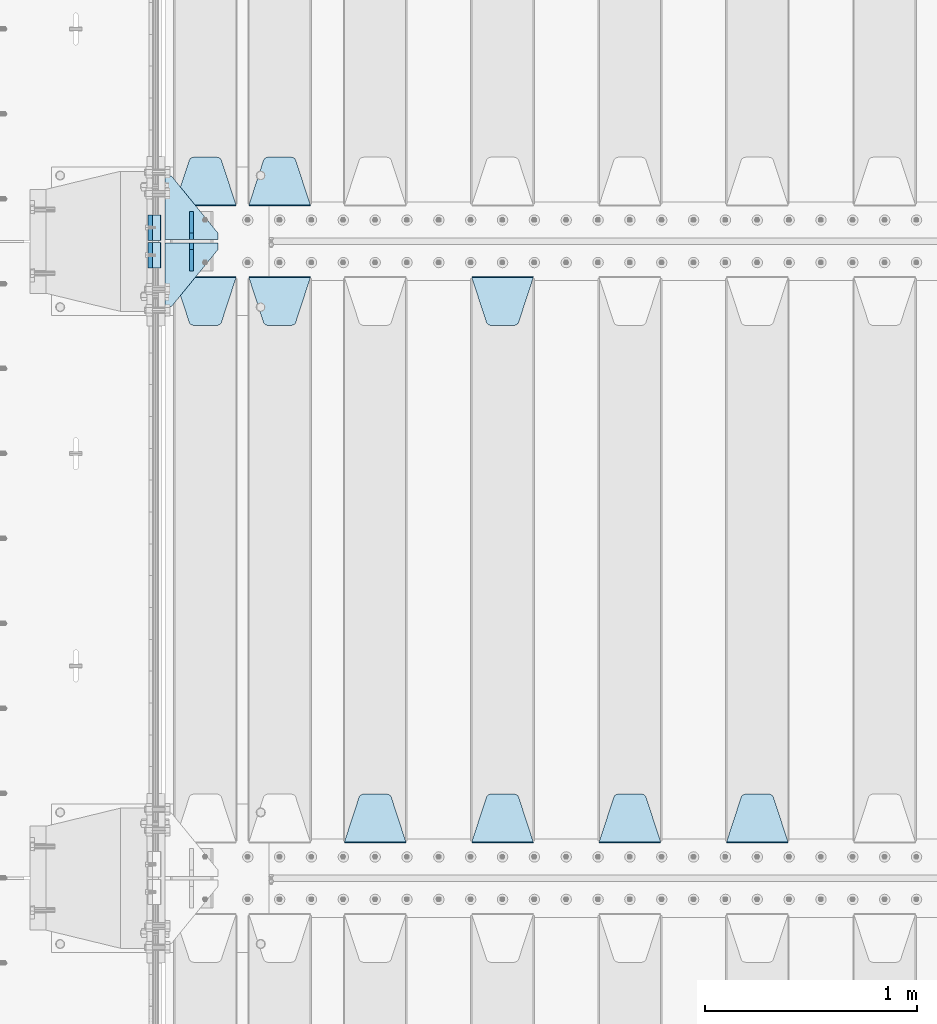
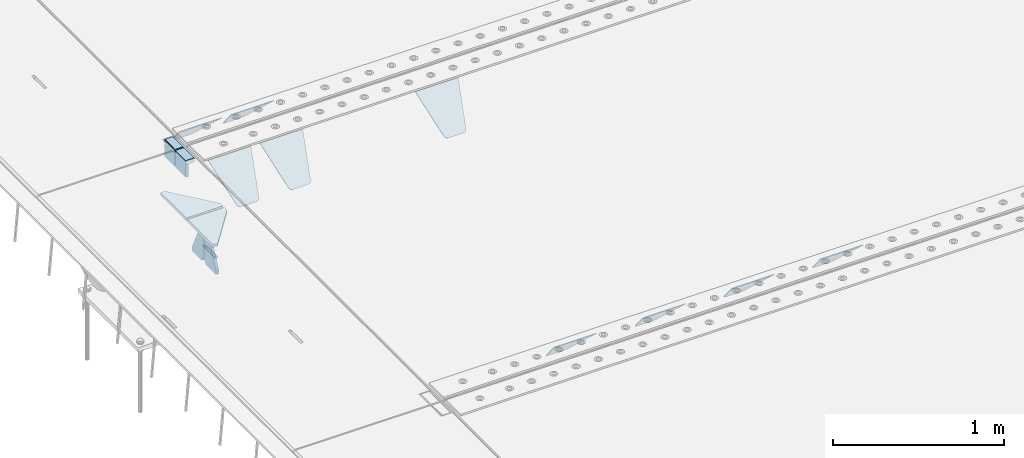
# One storey, part 194 of 240: 17 plates.
"""IFC2X3 building model written with IfcOpenShell, lengths in millimetres."""

import ifcopenshell
import ifcopenshell.guid

model = None  # the IFC model being written
_history = None  # IfcOwnerHistory: only IFC2X3 demands one
_inside = {}  # id of a spatial element -> (the spatial element, [elements in it])
_under = {}  # id of a project, library or spatial element -> (it, [spatial elements below it])
_declared = {}  # id of a project -> (the project, [libraries it declares])
_typed = {}  # id of a type object -> (the type object, [elements of that type])
_made_of = {}  # id of a material, layer set ... -> (it, [elements and type objects made of it])


def new_model(schema):
    """Start an empty IFC model of exactly this schema.

    Asked for "IFC4X3", IfcOpenShell would pick the latest addendum, in which some entities
    have other attributes; the version numbers below select the first issue.
    IFC2X3 requires an IfcOwnerHistory on every rooted entity: one is made here for all.
    """
    global model, _history
    if schema == "IFC4X3":
        model = ifcopenshell.file(schema_version=(4, 3, 0, 0))
    else:
        model = ifcopenshell.file(schema=schema)
    _inside.clear()
    _under.clear()
    _declared.clear()
    _typed.clear()
    _made_of.clear()
    _history = None
    if model.schema == "IFC2X3":
        org = make("IfcOrganization", Name="unknown")
        user = make(
            "IfcPersonAndOrganization",
            ThePerson=make("IfcPerson", FamilyName="unknown"),
            TheOrganization=org,
        )
        app = make(
            "IfcApplication",
            ApplicationDeveloper=org,
            Version="unknown",
            ApplicationFullName="unknown",
            ApplicationIdentifier="unknown",
        )
        _history = make(
            "IfcOwnerHistory",
            OwningUser=user,
            OwningApplication=app,
            ChangeAction="ADDED",
            CreationDate=0,
        )
    return model


def make(cls, **values):
    """One entity of the class cls with the attributes given. An attribute that is None is left unset."""
    return model.create_entity(
        cls, **{name: value for name, value in values.items() if value is not None}
    )


def rooted(cls, **values):
    """An entity with a GlobalId (a new one), such as an element, a storey or a relation."""
    return make(cls, GlobalId=ifcopenshell.guid.new(), OwnerHistory=_history, **values)


def si_unit(unit_type, name, prefix=None):
    """IfcSIUnit, for example si_unit("LENGTHUNIT", "METRE", prefix="MILLI")."""
    return make("IfcSIUnit", UnitType=unit_type, Prefix=prefix, Name=name)


def assignment(units):
    """IfcUnitAssignment: the units of a project."""
    return None if units is None else make("IfcUnitAssignment", Units=units)


def point(xyz):
    """IfcCartesianPoint."""
    return None if xyz is None else make("IfcCartesianPoint", Coordinates=xyz)


def direction(xyz):
    """IfcDirection."""
    return None if xyz is None else make("IfcDirection", DirectionRatios=xyz)


def frame(location, z_axis=None, x_axis=None):
    """IfcAxis2Placement3D, a coordinate frame: its origin and axes. An axis left out is left unset."""
    return make(
        "IfcAxis2Placement3D",
        Location=point(location),
        Axis=direction(z_axis),
        RefDirection=direction(x_axis),
    )


def origin_with_axes():
    """The frame at (0, 0, 0) with the z axis (0, 0, 1) and the x axis (1, 0, 0) written out."""
    return frame((0.0, 0.0, 0.0), z_axis=(0.0, 0.0, 1.0), x_axis=(1.0, 0.0, 0.0))


def place(relative_to, where):
    """IfcLocalPlacement: puts the frame where relative to a parent placement (None: the world)."""
    return make(
        "IfcLocalPlacement", PlacementRelTo=relative_to, RelativePlacement=where
    )


def context(
    kind, dimensions, precision=None, world=None, true_north=None, identifier=None
):
    """IfcGeometricRepresentationContext, for example the 3D "Model" context."""
    return make(
        "IfcGeometricRepresentationContext",
        ContextIdentifier=identifier,
        ContextType=kind,
        CoordinateSpaceDimension=dimensions,
        Precision=precision,
        WorldCoordinateSystem=world,
        TrueNorth=true_north,
    )


def subcontext(parent, identifier, kind, view, scale=None):
    """IfcGeometricRepresentationSubContext, for example "Body" below "Model"."""
    return make(
        "IfcGeometricRepresentationSubContext",
        ContextIdentifier=identifier,
        ContextType=kind,
        ParentContext=parent,
        TargetScale=scale,
        TargetView=view,
    )


def project(units=None, contexts=None):
    """IfcProject with its units and contexts."""
    return rooted(
        "IfcProject",
        Name="project",
        RepresentationContexts=contexts,
        UnitsInContext=assignment(units),
    )


def spatial(cls, under=None, at=None, **own):
    """A site, building, storey or space (cls), placed at a placement, below another one or the project."""
    s = rooted(cls, ObjectPlacement=at, **own)
    if under is not None:
        _under.setdefault(under.id(), (under, []))[1].append(s)
    return s


def faces_of(points, faces, orient=None, outer=None):
    """IfcFace entities. A face is a list of loops; a loop is a list of indices into points, from 0.

    orient and outer hold one flag for each loop. By default every Orientation is true, the
    first loop of a face is its IfcFaceOuterBound and the others are IfcFaceBound.
    """
    made = []
    for i, loops in enumerate(faces):
        bounds = []
        for j, loop in enumerate(loops):
            is_outer = j == 0 if outer is None else outer[i][j]
            bounds.append(
                make(
                    "IfcFaceOuterBound" if is_outer else "IfcFaceBound",
                    Bound=make("IfcPolyLoop", Polygon=[points[k] for k in loop]),
                    Orientation=True if orient is None else orient[i][j],
                )
            )
        made.append(make("IfcFace", Bounds=bounds))
    return made


def faceted_brep(points, faces, orient=None, outer=None, voids=None):
    """IfcFacetedBrep: a solid bounded by flat faces; with voids (closed shells), ...WithVoids."""
    shared = [point(p) for p in points]
    hull = make("IfcClosedShell", CfsFaces=faces_of(shared, faces, orient, outer))
    if voids is None:
        return make("IfcFacetedBrep", Outer=hull)
    return make(
        "IfcFacetedBrepWithVoids",
        Outer=hull,
        Voids=[
            make(cls, CfsFaces=faces_of(shared, fs, o, b)) for cls, fs, o, b in voids
        ],
    )


def shape(context_of_items, identifier, shape_type, items):
    """IfcShapeRepresentation: the items that make up one representation, for example the "Body"."""
    return make(
        "IfcShapeRepresentation",
        ContextOfItems=context_of_items,
        RepresentationIdentifier=identifier,
        RepresentationType=shape_type,
        Items=items,
    )


def material(Name=None, Category=None):
    """IfcMaterial."""
    return make("IfcMaterial", Name=Name, Category=Category)


def made_of(thing, what):
    """Note that an element or type object is made of a material, layer set ...; save() writes the relation."""
    if what is not None:
        _made_of.setdefault(what.id(), (what, []))[1].append(thing)
    return thing


def type_object(cls, material=None, **own):
    """A type object (cls), such as IfcWallType, which elements share."""
    return made_of(rooted(cls, **own), material)


def element(
    cls,
    number,
    at=None,
    inside=None,
    cuts=None,
    type_object=None,
    material=None,
    context=None,
    identifier="Body",
    shape_type=None,
    held_by="IfcProductDefinitionShape",
    body=None,
    shapes=None,
    **own,
):
    """One element of the class cls, such as IfcWall. Its Tag is "e" and its number.

    at: its placement. inside: the storey or other place that contains it. cuts: it is an
    opening in that element (IfcRelVoidsElement). A single representation is given by context,
    identifier, shape_type and body (its items); several are given by shapes. held_by: the class
    of the entity that holds the representations. save() writes the other relations.
    """
    e = rooted(cls, Tag="e%d" % number, ObjectPlacement=at, **own)
    if body is not None:
        shapes = [shape(context, identifier, shape_type, body)]
    if shapes is not None:
        e.Representation = make(held_by, Representations=shapes)
    if inside is not None:
        _inside.setdefault(inside.id(), (inside, []))[1].append(e)
    if cuts is not None:
        rooted(
            "IfcRelVoidsElement", RelatingBuildingElement=cuts, RelatedOpeningElement=e
        )
    if type_object is not None:
        _typed.setdefault(type_object.id(), (type_object, []))[1].append(e)
    return made_of(e, material)


def aggregate(whole, parts):
    """IfcRelAggregates: a whole, such as a stair, and the parts it consists of."""
    return rooted("IfcRelAggregates", RelatingObject=whole, RelatedObjects=parts)


def save(model, path):
    """Write the relations noted so far, then the file.

    IfcRelAggregates (storeys below a building ...), IfcRelContainedInSpatialStructure (elements
    in a storey), IfcRelDefinesByType, IfcRelAssociatesMaterial and IfcRelDeclares: one each for
    every whole, place, type object, material and project.
    """
    for whole, parts in _under.values():
        aggregate(whole, parts)
    for where, things in _inside.values():
        rooted(
            "IfcRelContainedInSpatialStructure",
            RelatedElements=things,
            RelatingStructure=where,
        )
    for kind, things in _typed.values():
        rooted("IfcRelDefinesByType", RelatedObjects=things, RelatingType=kind)
    for what, things in _made_of.values():
        rooted("IfcRelAssociatesMaterial", RelatedObjects=things, RelatingMaterial=what)
    for by, libraries in _declared.values():
        rooted("IfcRelDeclares", RelatingContext=by, RelatedDefinitions=libraries)
    model.write(path)


model = new_model("IFC2X3")

# Units and contexts
model_context = context("Model", 3, precision=1e-05, world=origin_with_axes())
body_context = subcontext(model_context, "Body", "Model", "MODEL_VIEW")
ifc_project = project(units=[si_unit("LENGTHUNIT", "METRE", prefix="MILLI"), si_unit("AREAUNIT", "SQUARE_METRE"), si_unit("VOLUMEUNIT", "CUBIC_METRE"), si_unit("MASSUNIT", "GRAM", prefix="KILO"), si_unit("TIMEUNIT", "SECOND"), si_unit("PLANEANGLEUNIT", "RADIAN"), si_unit("SOLIDANGLEUNIT", "STERADIAN"), si_unit("THERMODYNAMICTEMPERATUREUNIT", "DEGREE_CELSIUS"), si_unit("LUMINOUSINTENSITYUNIT", "LUMEN")], contexts=[model_context])

# Site, building, storey
site_placement = place(None, origin_with_axes())
site = spatial("IfcSite", under=ifc_project, at=site_placement, CompositionType="ELEMENT")
building_placement = place(site_placement, origin_with_axes())
building = spatial("IfcBuilding", under=site, at=building_placement, Name="Standard", CompositionType="ELEMENT")
storey_placement = place(building_placement, origin_with_axes())
storey = spatial("IfcBuildingStorey", under=building, at=storey_placement, Name="Undefined", CompositionType="ELEMENT", Elevation=0.0)

# Plates
ifc_material_1 = material()
plate_type_1 = type_object("IfcPlateType", PredefinedType="NOTDEFINED")
for number, where, z_axis, x_axis in (
    (1, (42440.0000000598, 29935.0000004334, -16.0004050746771), (-1.0, 0.0, 0.0), (0.0, -4.95099997756316e-06, 0.999999999987744)),
    (2, (42439.99999994, 30065.0000004521, -16.0145962164398), (-1.0, 0.0, 0.0), (0.0, -4.95099997756316e-06, 0.999999999987744)),
):
    element("IfcPlate", number, at=place(storey_placement, frame(where, z_axis=z_axis, x_axis=x_axis)), inside=storey, type_object=plate_type_1, material=ifc_material_1, context=body_context, shape_type="Brep", body=[
        faceted_brep([(3.5527136788005e-15, -60.0, 0.0), (-0.000933120085687023, -60.0000000000036, 60.0), (-0.000933120085687023, 60.0, 59.9999999999927), (0.0, 60.0000000000036, -7.27595761418343e-12), (24.9991450303709, -60.0, 60.0), (24.9991450303709, 59.9999999999964, 59.9999999999927), (26.544215218168, -60.0000000000036, 59.7552873850873), (26.544215218168, 60.0, 59.75528738508), (27.9380461396139, -60.0, 59.0451032459096), (27.9380461396139, 60.0, 59.0451032459096), (29.0442025908961, -60.0, 57.9389639895744), (29.0442025908961, 60.0, 57.9389639895744), (29.7544083969366, -60.0, 56.5451441080368), (29.7544083969366, 60.0000000000036, 56.5451441080295), (29.9991450297669, -60.0000000000036, 55.0000777244568), (29.9991450297669, 60.0, 55.0000777244495), (29.999922274335, -60.0, 5.00007772445679), (29.999922274335, 60.0, 5.00007772444951), (29.7552240705896, -60.0000000000036, 3.45497416452417), (29.7552240705896, 60.0, 3.45497416452417), (29.0450346578116, -60.0, 2.06111146690819), (29.0450346578116, 60.0, 2.06111146690819), (27.9388736885073, -60.0, 0.954933302316931), (27.9388736885072, 59.9999999999964, 0.954933302316931), (26.5450220308766, -60.0000000000036, 0.244722222181736), (26.5450220308766, 60.0, 0.244722222181736), (24.9999222749392, -59.9999999999964, 0.0), (24.9999222749392, 60.0, -7.27595761418343e-12)], [[[0, 1, 2, 3]], [[1, 4, 5, 2]], [[4, 6, 7, 5]], [[6, 8, 9, 7]], [[8, 10, 11, 9]], [[10, 12, 13, 11]], [[12, 14, 15, 13]], [[14, 16, 17, 15]], [[16, 18, 19, 17]], [[18, 20, 21, 19]], [[20, 22, 23, 21]], [[22, 24, 25, 23]], [[24, 26, 27, 25]], [[26, 0, 3, 27]], [[5, 7, 9, 11, 13, 15, 17, 19, 21, 23, 25, 27, 3, 2]], [[26, 24, 22, 20, 18, 16, 14, 12, 10, 8, 6, 4, 1, 0]]]),
    ])
ifc_material_2 = material(Name="STEEL/S355N")
plate_type_2 = type_object("IfcPlateType", PredefinedType="NOTDEFINED")
for number, where, z_axis, x_axis in (
    (3, (42390.0, 29995.0004459832, -106.000730104157), (0.0, -0.999999999987744, -4.95099999993769e-06), (0.0, -4.95099997756316e-06, 0.999999999987744)),
    (4, (42390.0, 30125.000446002, -106.014921246643), (0.0, -0.999999999987744, -4.95099999993769e-06), (0.0, -4.95099997756316e-06, 0.999999999987744)),
):
    element("IfcPlate", number, at=place(storey_placement, frame(where, z_axis=z_axis, x_axis=x_axis)), inside=storey, type_object=plate_type_2, material=ifc_material_2, context=body_context, shape_type="Brep", body=[
        faceted_brep([(0.0, -10.0, 0.0), (5.70725632087488e-07, -10.0, 119.999999999993), (5.70725632087488e-07, 10.0, 119.999999999993), (0.0, 10.0, 0.0), (89.9999999999979, -10.0, 120.0), (89.9999999999979, 10.0, 120.0), (90.0, -10.0, 1.09139364212751e-11), (90.0, 10.0, 1.09139364212751e-11)], [[[0, 1, 2, 3]], [[1, 4, 5, 2]], [[4, 6, 7, 5]], [[6, 0, 3, 7]], [[5, 7, 3, 2]], [[6, 4, 1, 0]]]),
    ])
plate_type_3 = type_object("IfcPlateType", PredefinedType="NOTDEFINED")
plate_1_placement = place(storey_placement, frame((43145.0, 30168.232233047, -1.76776695296758), z_axis=(0.0, 0.707106781186547, -0.707106781186548), x_axis=(-1.0, 0.0, 0.0)))
element("IfcPlate", 5, at=plate_1_placement, inside=storey, type_object=plate_type_3, material=ifc_material_2, context=body_context, shape_type="Brep", body=[
    faceted_brep([(0.0, -2.5, 0.0), (69.345504679477, -2.50000000000364, 300.171731424827), (69.345504679477, 2.49999999999636, 300.171731424827), (0.0, 2.5, 0.0), (70.927406119954, -2.50000000000364, 304.897442415397), (70.927406119954, 2.49999999999636, 304.897442415397), (73.3818627772271, -2.50000000000728, 309.234538108525), (73.3818627772271, 2.49999999999636, 309.234538108529), (76.6187032999587, -2.50000000000728, 313.023683126099), (76.6187032999587, 2.49999999999636, 313.023683126103), (80.5190132705029, -2.50000000000364, 316.125672595368), (80.5190132705029, 2.49999999999636, 316.125672595368), (84.9395038596849, -2.50000000000364, 318.426546230472), (84.9395038596849, 2.49999999999636, 318.426546230472), (89.7177759439219, -2.5, 319.841774983277), (89.7177759439219, 2.49999999999636, 319.841774983273), (94.6782862926484, -2.50000000000364, 320.319366455074), (94.6782862926484, 2.49999999999636, 320.319366455074), (195.321713707352, -2.50000000000364, 320.319366455074), (195.321713707352, 2.49999999999636, 320.319366455074), (200.282224056078, -2.50000000000364, 319.841774983273), (200.282224056078, 2.49999999999636, 319.841774983273), (205.060496140315, -2.50000000000364, 318.426546230472), (205.060496140315, 2.49999999999636, 318.426546230472), (209.480986729497, -2.50000000000364, 316.125672595368), (209.480986729497, 2.49999999999636, 316.125672595368), (213.381296700041, -2.50000000000728, 313.023683126099), (213.381296700041, 2.49999999999272, 313.023683126099), (216.618137222766, -2.50000000000364, 309.234538108522), (216.618137222766, 2.49999999999636, 309.234538108522), (219.072593880039, -2.50000000000364, 304.897442415397), (219.072593880039, 2.49999999999636, 304.897442415397), (220.654495320523, -2.50000000000364, 300.171731424827), (220.654495320523, 2.49999999999636, 300.171731424827), (290.0, -2.50000000000364, -3.63797880709171e-12), (290.0, 2.49999999999636, -3.63797880709171e-12)], [[[0, 1, 2, 3]], [[1, 4, 5, 2]], [[4, 6, 7, 5]], [[6, 8, 9, 7]], [[8, 10, 11, 9]], [[10, 12, 13, 11]], [[12, 14, 15, 13]], [[14, 16, 17, 15]], [[16, 18, 19, 17]], [[18, 20, 21, 19]], [[20, 22, 23, 21]], [[22, 24, 25, 23]], [[24, 26, 27, 25]], [[26, 28, 29, 27]], [[28, 30, 31, 29]], [[30, 32, 33, 31]], [[32, 34, 35, 33]], [[34, 0, 3, 35]], [[5, 7, 9, 11, 13, 15, 17, 19, 21, 23, 25, 27, 29, 31, 33, 35, 3, 2]], [[34, 32, 30, 28, 26, 24, 22, 20, 18, 16, 14, 12, 10, 8, 6, 4, 1, 0]]]),
])
plate_2_placement = place(storey_placement, frame((45395.0, 27168.232233047, -1.76776695296758), z_axis=(0.0, 0.707106781186547, -0.707106781186548), x_axis=(-1.0, 0.0, 0.0)))
element("IfcPlate", 6, at=plate_2_placement, inside=storey, type_object=plate_type_3, material=ifc_material_2, context=body_context, shape_type="Brep", body=[
    faceted_brep([(0.0, -2.5, 0.0), (69.345504679477, -2.50000000000364, 300.171731424827), (69.345504679477, 2.49999999999636, 300.171731424827), (0.0, 2.5, 0.0), (70.927406119954, -2.50000000000364, 304.897442415397), (70.927406119954, 2.49999999999636, 304.897442415397), (73.3818627772271, -2.50000000000728, 309.234538108525), (73.3818627772271, 2.49999999999636, 309.234538108529), (76.6187032999587, -2.50000000000728, 313.023683126099), (76.6187032999587, 2.49999999999636, 313.023683126103), (80.5190132705029, -2.50000000000364, 316.125672595368), (80.5190132705029, 2.49999999999636, 316.125672595368), (84.9395038596849, -2.50000000000364, 318.426546230472), (84.9395038596849, 2.49999999999636, 318.426546230472), (89.7177759439219, -2.5, 319.841774983277), (89.7177759439219, 2.49999999999636, 319.841774983273), (94.6782862926484, -2.50000000000364, 320.319366455074), (94.6782862926484, 2.49999999999636, 320.319366455074), (195.321713707352, -2.50000000000364, 320.319366455074), (195.321713707352, 2.49999999999636, 320.319366455074), (200.282224056078, -2.50000000000364, 319.841774983273), (200.282224056078, 2.49999999999636, 319.841774983273), (205.060496140315, -2.50000000000364, 318.426546230472), (205.060496140315, 2.49999999999636, 318.426546230472), (209.480986729497, -2.50000000000364, 316.125672595368), (209.480986729497, 2.49999999999636, 316.125672595368), (213.381296700041, -2.50000000000728, 313.023683126099), (213.381296700041, 2.49999999999272, 313.023683126099), (216.618137222766, -2.50000000000364, 309.234538108522), (216.618137222766, 2.49999999999636, 309.234538108522), (219.072593880039, -2.50000000000364, 304.897442415397), (219.072593880039, 2.49999999999636, 304.897442415397), (220.654495320523, -2.50000000000364, 300.171731424827), (220.654495320523, 2.49999999999636, 300.171731424827), (290.0, -2.50000000000364, -3.63797880709171e-12), (290.0, 2.49999999999636, -3.63797880709171e-12)], [[[0, 1, 2, 3]], [[1, 4, 5, 2]], [[4, 6, 7, 5]], [[6, 8, 9, 7]], [[8, 10, 11, 9]], [[10, 12, 13, 11]], [[12, 14, 15, 13]], [[14, 16, 17, 15]], [[16, 18, 19, 17]], [[18, 20, 21, 19]], [[20, 22, 23, 21]], [[22, 24, 25, 23]], [[24, 26, 27, 25]], [[26, 28, 29, 27]], [[28, 30, 31, 29]], [[30, 32, 33, 31]], [[32, 34, 35, 33]], [[34, 0, 3, 35]], [[5, 7, 9, 11, 13, 15, 17, 19, 21, 23, 25, 27, 29, 31, 33, 35, 3, 2]], [[34, 32, 30, 28, 26, 24, 22, 20, 18, 16, 14, 12, 10, 8, 6, 4, 1, 0]]]),
])
plate_3_placement = place(storey_placement, frame((44795.0, 27168.232233047, -1.76776695296758), z_axis=(0.0, 0.707106781186547, -0.707106781186548), x_axis=(-1.0, 0.0, 0.0)))
element("IfcPlate", 7, at=plate_3_placement, inside=storey, type_object=plate_type_3, material=ifc_material_2, context=body_context, shape_type="Brep", body=[
    faceted_brep([(0.0, -2.5, 0.0), (69.345504679477, -2.50000000000364, 300.171731424827), (69.345504679477, 2.49999999999636, 300.171731424827), (0.0, 2.5, 0.0), (70.927406119954, -2.50000000000364, 304.897442415397), (70.927406119954, 2.49999999999636, 304.897442415397), (73.3818627772271, -2.50000000000728, 309.234538108525), (73.3818627772271, 2.49999999999636, 309.234538108529), (76.6187032999587, -2.50000000000728, 313.023683126099), (76.6187032999587, 2.49999999999636, 313.023683126103), (80.5190132705029, -2.50000000000364, 316.125672595368), (80.5190132705029, 2.49999999999636, 316.125672595368), (84.9395038596849, -2.50000000000364, 318.426546230472), (84.9395038596849, 2.49999999999636, 318.426546230472), (89.7177759439219, -2.5, 319.841774983277), (89.7177759439219, 2.49999999999636, 319.841774983273), (94.6782862926484, -2.50000000000364, 320.319366455074), (94.6782862926484, 2.49999999999636, 320.319366455074), (195.321713707352, -2.50000000000364, 320.319366455074), (195.321713707352, 2.49999999999636, 320.319366455074), (200.282224056078, -2.50000000000364, 319.841774983273), (200.282224056078, 2.49999999999636, 319.841774983273), (205.060496140315, -2.50000000000364, 318.426546230472), (205.060496140315, 2.49999999999636, 318.426546230472), (209.480986729497, -2.50000000000364, 316.125672595368), (209.480986729497, 2.49999999999636, 316.125672595368), (213.381296700041, -2.50000000000728, 313.023683126099), (213.381296700041, 2.49999999999272, 313.023683126099), (216.618137222766, -2.50000000000364, 309.234538108522), (216.618137222766, 2.49999999999636, 309.234538108522), (219.072593880039, -2.50000000000364, 304.897442415397), (219.072593880039, 2.49999999999636, 304.897442415397), (220.654495320523, -2.50000000000364, 300.171731424827), (220.654495320523, 2.49999999999636, 300.171731424827), (290.0, -2.50000000000364, -3.63797880709171e-12), (290.0, 2.49999999999636, -3.63797880709171e-12)], [[[0, 1, 2, 3]], [[1, 4, 5, 2]], [[4, 6, 7, 5]], [[6, 8, 9, 7]], [[8, 10, 11, 9]], [[10, 12, 13, 11]], [[12, 14, 15, 13]], [[14, 16, 17, 15]], [[16, 18, 19, 17]], [[18, 20, 21, 19]], [[20, 22, 23, 21]], [[22, 24, 25, 23]], [[24, 26, 27, 25]], [[26, 28, 29, 27]], [[28, 30, 31, 29]], [[30, 32, 33, 31]], [[32, 34, 35, 33]], [[34, 0, 3, 35]], [[5, 7, 9, 11, 13, 15, 17, 19, 21, 23, 25, 27, 29, 31, 33, 35, 3, 2]], [[34, 32, 30, 28, 26, 24, 22, 20, 18, 16, 14, 12, 10, 8, 6, 4, 1, 0]]]),
])
plate_4_placement = place(storey_placement, frame((43905.0, 29831.767766956, -1.76776695296758), z_axis=(0.0, -0.707106781186547, -0.707106781186548), x_axis=(1.0, 0.0, 0.0)))
element("IfcPlate", 8, at=plate_4_placement, inside=storey, type_object=plate_type_3, material=ifc_material_2, context=body_context, shape_type="Brep", body=[
    faceted_brep([(0.0, -2.5, 0.0), (69.345504679477, -2.50000000000364, 300.171731424827), (69.345504679477, 2.49999999999636, 300.171731424827), (0.0, 2.5, 0.0), (70.927406119954, -2.50000000000364, 304.897442415397), (70.927406119954, 2.49999999999636, 304.897442415397), (73.3818627772271, -2.50000000000728, 309.234538108525), (73.3818627772271, 2.49999999999636, 309.234538108529), (76.6187032999587, -2.50000000000728, 313.023683126099), (76.6187032999587, 2.49999999999636, 313.023683126103), (80.5190132705029, -2.50000000000364, 316.125672595368), (80.5190132705029, 2.49999999999636, 316.125672595368), (84.9395038596849, -2.50000000000364, 318.426546230472), (84.9395038596849, 2.49999999999636, 318.426546230472), (89.7177759439219, -2.5, 319.841774983277), (89.7177759439219, 2.49999999999636, 319.841774983273), (94.6782862926484, -2.50000000000364, 320.319366455074), (94.6782862926484, 2.49999999999636, 320.319366455074), (195.321713707352, -2.50000000000364, 320.319366455074), (195.321713707352, 2.49999999999636, 320.319366455074), (200.282224056078, -2.50000000000364, 319.841774983273), (200.282224056078, 2.49999999999636, 319.841774983273), (205.060496140315, -2.50000000000364, 318.426546230472), (205.060496140315, 2.49999999999636, 318.426546230472), (209.480986729497, -2.50000000000364, 316.125672595368), (209.480986729497, 2.49999999999636, 316.125672595368), (213.381296700041, -2.50000000000728, 313.023683126099), (213.381296700041, 2.49999999999272, 313.023683126099), (216.618137222766, -2.50000000000364, 309.234538108522), (216.618137222766, 2.49999999999636, 309.234538108522), (219.072593880039, -2.50000000000364, 304.897442415397), (219.072593880039, 2.49999999999636, 304.897442415397), (220.654495320523, -2.50000000000364, 300.171731424827), (220.654495320523, 2.49999999999636, 300.171731424827), (290.0, -2.50000000000364, -3.63797880709171e-12), (290.0, 2.49999999999636, -3.63797880709171e-12)], [[[0, 1, 2, 3]], [[1, 4, 5, 2]], [[4, 6, 7, 5]], [[6, 8, 9, 7]], [[8, 10, 11, 9]], [[10, 12, 13, 11]], [[12, 14, 15, 13]], [[14, 16, 17, 15]], [[16, 18, 19, 17]], [[18, 20, 21, 19]], [[20, 22, 23, 21]], [[22, 24, 25, 23]], [[24, 26, 27, 25]], [[26, 28, 29, 27]], [[28, 30, 31, 29]], [[30, 32, 33, 31]], [[32, 34, 35, 33]], [[34, 0, 3, 35]], [[5, 7, 9, 11, 13, 15, 17, 19, 21, 23, 25, 27, 29, 31, 33, 35, 3, 2]], [[34, 32, 30, 28, 26, 24, 22, 20, 18, 16, 14, 12, 10, 8, 6, 4, 1, 0]]]),
])
plate_5_placement = place(storey_placement, frame((44195.0, 27168.232233047, -1.76776695296758), z_axis=(0.0, 0.707106781186547, -0.707106781186548), x_axis=(-1.0, 0.0, 0.0)))
element("IfcPlate", 9, at=plate_5_placement, inside=storey, type_object=plate_type_3, material=ifc_material_2, context=body_context, shape_type="Brep", body=[
    faceted_brep([(0.0, -2.5, 0.0), (69.345504679477, -2.50000000000364, 300.171731424827), (69.345504679477, 2.49999999999636, 300.171731424827), (0.0, 2.5, 0.0), (70.927406119954, -2.50000000000364, 304.897442415397), (70.927406119954, 2.49999999999636, 304.897442415397), (73.3818627772271, -2.50000000000728, 309.234538108525), (73.3818627772271, 2.49999999999636, 309.234538108529), (76.6187032999587, -2.50000000000728, 313.023683126099), (76.6187032999587, 2.49999999999636, 313.023683126103), (80.5190132705029, -2.50000000000364, 316.125672595368), (80.5190132705029, 2.49999999999636, 316.125672595368), (84.9395038596849, -2.50000000000364, 318.426546230472), (84.9395038596849, 2.49999999999636, 318.426546230472), (89.7177759439219, -2.5, 319.841774983277), (89.7177759439219, 2.49999999999636, 319.841774983273), (94.6782862926484, -2.50000000000364, 320.319366455074), (94.6782862926484, 2.49999999999636, 320.319366455074), (195.321713707352, -2.50000000000364, 320.319366455074), (195.321713707352, 2.49999999999636, 320.319366455074), (200.282224056078, -2.50000000000364, 319.841774983273), (200.282224056078, 2.49999999999636, 319.841774983273), (205.060496140315, -2.50000000000364, 318.426546230472), (205.060496140315, 2.49999999999636, 318.426546230472), (209.480986729497, -2.50000000000364, 316.125672595368), (209.480986729497, 2.49999999999636, 316.125672595368), (213.381296700041, -2.50000000000728, 313.023683126099), (213.381296700041, 2.49999999999272, 313.023683126099), (216.618137222766, -2.50000000000364, 309.234538108522), (216.618137222766, 2.49999999999636, 309.234538108522), (219.072593880039, -2.50000000000364, 304.897442415397), (219.072593880039, 2.49999999999636, 304.897442415397), (220.654495320523, -2.50000000000364, 300.171731424827), (220.654495320523, 2.49999999999636, 300.171731424827), (290.0, -2.50000000000364, -3.63797880709171e-12), (290.0, 2.49999999999636, -3.63797880709171e-12)], [[[0, 1, 2, 3]], [[1, 4, 5, 2]], [[4, 6, 7, 5]], [[6, 8, 9, 7]], [[8, 10, 11, 9]], [[10, 12, 13, 11]], [[12, 14, 15, 13]], [[14, 16, 17, 15]], [[16, 18, 19, 17]], [[18, 20, 21, 19]], [[20, 22, 23, 21]], [[22, 24, 25, 23]], [[24, 26, 27, 25]], [[26, 28, 29, 27]], [[28, 30, 31, 29]], [[30, 32, 33, 31]], [[32, 34, 35, 33]], [[34, 0, 3, 35]], [[5, 7, 9, 11, 13, 15, 17, 19, 21, 23, 25, 27, 29, 31, 33, 35, 3, 2]], [[34, 32, 30, 28, 26, 24, 22, 20, 18, 16, 14, 12, 10, 8, 6, 4, 1, 0]]]),
])
plate_6_placement = place(storey_placement, frame((43595.0, 27168.232233047, -1.76776695296758), z_axis=(0.0, 0.707106781186547, -0.707106781186548), x_axis=(-1.0, 0.0, 0.0)))
element("IfcPlate", 10, at=plate_6_placement, inside=storey, type_object=plate_type_3, material=ifc_material_2, context=body_context, shape_type="Brep", body=[
    faceted_brep([(0.0, -2.5, 0.0), (69.345504679477, -2.50000000000364, 300.171731424827), (69.345504679477, 2.49999999999636, 300.171731424827), (0.0, 2.5, 0.0), (70.927406119954, -2.50000000000364, 304.897442415397), (70.927406119954, 2.49999999999636, 304.897442415397), (73.3818627772271, -2.50000000000728, 309.234538108525), (73.3818627772271, 2.49999999999636, 309.234538108529), (76.6187032999587, -2.50000000000728, 313.023683126099), (76.6187032999587, 2.49999999999636, 313.023683126103), (80.5190132705029, -2.50000000000364, 316.125672595368), (80.5190132705029, 2.49999999999636, 316.125672595368), (84.9395038596849, -2.50000000000364, 318.426546230472), (84.9395038596849, 2.49999999999636, 318.426546230472), (89.7177759439219, -2.5, 319.841774983277), (89.7177759439219, 2.49999999999636, 319.841774983273), (94.6782862926484, -2.50000000000364, 320.319366455074), (94.6782862926484, 2.49999999999636, 320.319366455074), (195.321713707352, -2.50000000000364, 320.319366455074), (195.321713707352, 2.49999999999636, 320.319366455074), (200.282224056078, -2.50000000000364, 319.841774983273), (200.282224056078, 2.49999999999636, 319.841774983273), (205.060496140315, -2.50000000000364, 318.426546230472), (205.060496140315, 2.49999999999636, 318.426546230472), (209.480986729497, -2.50000000000364, 316.125672595368), (209.480986729497, 2.49999999999636, 316.125672595368), (213.381296700041, -2.50000000000728, 313.023683126099), (213.381296700041, 2.49999999999272, 313.023683126099), (216.618137222766, -2.50000000000364, 309.234538108522), (216.618137222766, 2.49999999999636, 309.234538108522), (219.072593880039, -2.50000000000364, 304.897442415397), (219.072593880039, 2.49999999999636, 304.897442415397), (220.654495320523, -2.50000000000364, 300.171731424827), (220.654495320523, 2.49999999999636, 300.171731424827), (290.0, -2.50000000000364, -3.63797880709171e-12), (290.0, 2.49999999999636, -3.63797880709171e-12)], [[[0, 1, 2, 3]], [[1, 4, 5, 2]], [[4, 6, 7, 5]], [[6, 8, 9, 7]], [[8, 10, 11, 9]], [[10, 12, 13, 11]], [[12, 14, 15, 13]], [[14, 16, 17, 15]], [[16, 18, 19, 17]], [[18, 20, 21, 19]], [[20, 22, 23, 21]], [[22, 24, 25, 23]], [[24, 26, 27, 25]], [[26, 28, 29, 27]], [[28, 30, 31, 29]], [[30, 32, 33, 31]], [[32, 34, 35, 33]], [[34, 0, 3, 35]], [[5, 7, 9, 11, 13, 15, 17, 19, 21, 23, 25, 27, 29, 31, 33, 35, 3, 2]], [[34, 32, 30, 28, 26, 24, 22, 20, 18, 16, 14, 12, 10, 8, 6, 4, 1, 0]]]),
])
plate_7_placement = place(storey_placement, frame((42855.0, 29831.767766956, -1.76776695296758), z_axis=(0.0, -0.707106781186547, -0.707106781186548), x_axis=(1.0, 0.0, 0.0)))
element("IfcPlate", 11, at=plate_7_placement, inside=storey, type_object=plate_type_3, material=ifc_material_2, context=body_context, shape_type="Brep", body=[
    faceted_brep([(0.0, -2.5, 0.0), (69.345504679477, -2.50000000000364, 300.171731424827), (69.345504679477, 2.49999999999636, 300.171731424827), (0.0, 2.5, 0.0), (70.927406119954, -2.50000000000364, 304.897442415397), (70.927406119954, 2.49999999999636, 304.897442415397), (73.3818627772271, -2.50000000000728, 309.234538108525), (73.3818627772271, 2.49999999999636, 309.234538108529), (76.6187032999587, -2.50000000000728, 313.023683126099), (76.6187032999587, 2.49999999999636, 313.023683126103), (80.5190132705029, -2.50000000000364, 316.125672595368), (80.5190132705029, 2.49999999999636, 316.125672595368), (84.9395038596849, -2.50000000000364, 318.426546230472), (84.9395038596849, 2.49999999999636, 318.426546230472), (89.7177759439219, -2.5, 319.841774983277), (89.7177759439219, 2.49999999999636, 319.841774983273), (94.6782862926484, -2.50000000000364, 320.319366455074), (94.6782862926484, 2.49999999999636, 320.319366455074), (195.321713707352, -2.50000000000364, 320.319366455074), (195.321713707352, 2.49999999999636, 320.319366455074), (200.282224056078, -2.50000000000364, 319.841774983273), (200.282224056078, 2.49999999999636, 319.841774983273), (205.060496140315, -2.50000000000364, 318.426546230472), (205.060496140315, 2.49999999999636, 318.426546230472), (209.480986729497, -2.50000000000364, 316.125672595368), (209.480986729497, 2.49999999999636, 316.125672595368), (213.381296700041, -2.50000000000728, 313.023683126099), (213.381296700041, 2.49999999999272, 313.023683126099), (216.618137222766, -2.50000000000364, 309.234538108522), (216.618137222766, 2.49999999999636, 309.234538108522), (219.072593880039, -2.50000000000364, 304.897442415397), (219.072593880039, 2.49999999999636, 304.897442415397), (220.654495320523, -2.50000000000364, 300.171731424827), (220.654495320523, 2.49999999999636, 300.171731424827), (290.0, -2.50000000000364, -3.63797880709171e-12), (290.0, 2.49999999999636, -3.63797880709171e-12)], [[[0, 1, 2, 3]], [[1, 4, 5, 2]], [[4, 6, 7, 5]], [[6, 8, 9, 7]], [[8, 10, 11, 9]], [[10, 12, 13, 11]], [[12, 14, 15, 13]], [[14, 16, 17, 15]], [[16, 18, 19, 17]], [[18, 20, 21, 19]], [[20, 22, 23, 21]], [[22, 24, 25, 23]], [[24, 26, 27, 25]], [[26, 28, 29, 27]], [[28, 30, 31, 29]], [[30, 32, 33, 31]], [[32, 34, 35, 33]], [[34, 0, 3, 35]], [[5, 7, 9, 11, 13, 15, 17, 19, 21, 23, 25, 27, 29, 31, 33, 35, 3, 2]], [[34, 32, 30, 28, 26, 24, 22, 20, 18, 16, 14, 12, 10, 8, 6, 4, 1, 0]]]),
])
plate_8_placement = place(storey_placement, frame((42795.0, 30168.232233047, -1.76776695296758), z_axis=(0.0, 0.707106781186547, -0.707106781186548), x_axis=(-1.0, 0.0, 0.0)))
element("IfcPlate", 12, at=plate_8_placement, inside=storey, type_object=plate_type_3, material=ifc_material_2, context=body_context, shape_type="Brep", body=[
    faceted_brep([(0.0, -2.5, 0.0), (69.345504679477, -2.50000000000364, 300.171731424827), (69.345504679477, 2.49999999999636, 300.171731424827), (0.0, 2.5, 0.0), (70.927406119954, -2.50000000000364, 304.897442415397), (70.927406119954, 2.49999999999636, 304.897442415397), (73.3818627772271, -2.50000000000728, 309.234538108525), (73.3818627772271, 2.49999999999636, 309.234538108529), (76.6187032999587, -2.50000000000728, 313.023683126099), (76.6187032999587, 2.49999999999636, 313.023683126103), (80.5190132705029, -2.50000000000364, 316.125672595368), (80.5190132705029, 2.49999999999636, 316.125672595368), (84.9395038596849, -2.50000000000364, 318.426546230472), (84.9395038596849, 2.49999999999636, 318.426546230472), (89.7177759439219, -2.5, 319.841774983277), (89.7177759439219, 2.49999999999636, 319.841774983273), (94.6782862926484, -2.50000000000364, 320.319366455074), (94.6782862926484, 2.49999999999636, 320.319366455074), (195.321713707352, -2.50000000000364, 320.319366455074), (195.321713707352, 2.49999999999636, 320.319366455074), (200.282224056078, -2.50000000000364, 319.841774983273), (200.282224056078, 2.49999999999636, 319.841774983273), (205.060496140315, -2.50000000000364, 318.426546230472), (205.060496140315, 2.49999999999636, 318.426546230472), (209.480986729497, -2.50000000000364, 316.125672595368), (209.480986729497, 2.49999999999636, 316.125672595368), (213.381296700041, -2.50000000000728, 313.023683126099), (213.381296700041, 2.49999999999272, 313.023683126099), (216.618137222766, -2.50000000000364, 309.234538108522), (216.618137222766, 2.49999999999636, 309.234538108522), (219.072593880039, -2.50000000000364, 304.897442415397), (219.072593880039, 2.49999999999636, 304.897442415397), (220.654495320523, -2.50000000000364, 300.171731424827), (220.654495320523, 2.49999999999636, 300.171731424827), (290.0, -2.50000000000364, -3.63797880709171e-12), (290.0, 2.49999999999636, -3.63797880709171e-12)], [[[0, 1, 2, 3]], [[1, 4, 5, 2]], [[4, 6, 7, 5]], [[6, 8, 9, 7]], [[8, 10, 11, 9]], [[10, 12, 13, 11]], [[12, 14, 15, 13]], [[14, 16, 17, 15]], [[16, 18, 19, 17]], [[18, 20, 21, 19]], [[20, 22, 23, 21]], [[22, 24, 25, 23]], [[24, 26, 27, 25]], [[26, 28, 29, 27]], [[28, 30, 31, 29]], [[30, 32, 33, 31]], [[32, 34, 35, 33]], [[34, 0, 3, 35]], [[5, 7, 9, 11, 13, 15, 17, 19, 21, 23, 25, 27, 29, 31, 33, 35, 3, 2]], [[34, 32, 30, 28, 26, 24, 22, 20, 18, 16, 14, 12, 10, 8, 6, 4, 1, 0]]]),
])
plate_9_placement = place(storey_placement, frame((42505.0, 29831.767766956, -1.76776695296758), z_axis=(0.0, -0.707106781186547, -0.707106781186548), x_axis=(1.0, 0.0, 0.0)))
element("IfcPlate", 13, at=plate_9_placement, inside=storey, type_object=plate_type_3, material=ifc_material_2, context=body_context, shape_type="Brep", body=[
    faceted_brep([(0.0, -2.5, 0.0), (69.345504679477, -2.50000000000364, 300.171731424827), (69.345504679477, 2.49999999999636, 300.171731424827), (0.0, 2.5, 0.0), (70.927406119954, -2.50000000000364, 304.897442415397), (70.927406119954, 2.49999999999636, 304.897442415397), (73.3818627772271, -2.50000000000728, 309.234538108525), (73.3818627772271, 2.49999999999636, 309.234538108529), (76.6187032999587, -2.50000000000728, 313.023683126099), (76.6187032999587, 2.49999999999636, 313.023683126103), (80.5190132705029, -2.50000000000364, 316.125672595368), (80.5190132705029, 2.49999999999636, 316.125672595368), (84.9395038596849, -2.50000000000364, 318.426546230472), (84.9395038596849, 2.49999999999636, 318.426546230472), (89.7177759439219, -2.5, 319.841774983277), (89.7177759439219, 2.49999999999636, 319.841774983273), (94.6782862926484, -2.50000000000364, 320.319366455074), (94.6782862926484, 2.49999999999636, 320.319366455074), (195.321713707352, -2.50000000000364, 320.319366455074), (195.321713707352, 2.49999999999636, 320.319366455074), (200.282224056078, -2.50000000000364, 319.841774983273), (200.282224056078, 2.49999999999636, 319.841774983273), (205.060496140315, -2.50000000000364, 318.426546230472), (205.060496140315, 2.49999999999636, 318.426546230472), (209.480986729497, -2.50000000000364, 316.125672595368), (209.480986729497, 2.49999999999636, 316.125672595368), (213.381296700041, -2.50000000000728, 313.023683126099), (213.381296700041, 2.49999999999272, 313.023683126099), (216.618137222766, -2.50000000000364, 309.234538108522), (216.618137222766, 2.49999999999636, 309.234538108522), (219.072593880039, -2.50000000000364, 304.897442415397), (219.072593880039, 2.49999999999636, 304.897442415397), (220.654495320523, -2.50000000000364, 300.171731424827), (220.654495320523, 2.49999999999636, 300.171731424827), (290.0, -2.50000000000364, -3.63797880709171e-12), (290.0, 2.49999999999636, -3.63797880709171e-12)], [[[0, 1, 2, 3]], [[1, 4, 5, 2]], [[4, 6, 7, 5]], [[6, 8, 9, 7]], [[8, 10, 11, 9]], [[10, 12, 13, 11]], [[12, 14, 15, 13]], [[14, 16, 17, 15]], [[16, 18, 19, 17]], [[18, 20, 21, 19]], [[20, 22, 23, 21]], [[22, 24, 25, 23]], [[24, 26, 27, 25]], [[26, 28, 29, 27]], [[28, 30, 31, 29]], [[30, 32, 33, 31]], [[32, 34, 35, 33]], [[34, 0, 3, 35]], [[5, 7, 9, 11, 13, 15, 17, 19, 21, 23, 25, 27, 29, 31, 33, 35, 3, 2]], [[34, 32, 30, 28, 26, 24, 22, 20, 18, 16, 14, 12, 10, 8, 6, 4, 1, 0]]]),
])
plate_type_4 = type_object("IfcPlateType", PredefinedType="NOTDEFINED")
for number, where, z_axis, x_axis in (
    (14, (42710.0, 30008.0, -515.0), (0.0, 1.0, 0.0), (-1.0, 0.0, 0.0)),
    (15, (42710.0, 29992.0, -515.0), (0.0, -1.0, 0.0), (-1.0, 0.0, 0.0)),
):
    element("IfcPlate", number, at=place(storey_placement, frame(where, z_axis=z_axis, x_axis=x_axis)), inside=storey, type_object=plate_type_4, material=ifc_material_2, context=body_context, shape_type="Brep", body=[
        faceted_brep([(0.0, -10.0, 0.0), (0.0, -10.0, 30.0), (0.0, 10.0, 30.0), (0.0, 10.0, 0.0), (220.0, -10.0, 300.0), (220.0, 10.0, 300.0), (250.0, -10.0, 300.0), (250.0, 10.0, 300.0), (250.0, -10.0, 0.0), (250.0, 10.0, 0.0)], [[[0, 1, 2, 3]], [[1, 4, 5, 2]], [[4, 6, 7, 5]], [[6, 8, 9, 7]], [[8, 0, 3, 9]], [[5, 7, 9, 3, 2]], [[8, 6, 4, 1, 0]]]),
    ])
plate_type_5 = type_object("IfcPlateType", PredefinedType="NOTDEFINED")
for number, where, z_axis, x_axis in (
    (16, (42585.0, 29860.0, -860.0), (0.0, 0.0, 1.0), (0.0, 1.0, 0.0)),
    (17, (42585.0, 30140.0, -860.0), (0.0, 0.0, 1.0), (0.0, -1.0, 0.0)),
):
    element("IfcPlate", number, at=place(storey_placement, frame(where, z_axis=z_axis, x_axis=x_axis)), inside=storey, type_object=plate_type_5, material=ifc_material_2, context=body_context, shape_type="Brep", body=[
        faceted_brep([(0.0, -10.0, 0.0), (0.0, -10.0, 30.0), (0.0, 10.0, 30.0), (0.0, 10.0, 0.0), (102.0, -10.0, 250.0), (102.0, 10.0, 250.0), (132.0, -10.0, 250.0), (132.0, 10.0, 250.0), (132.0, -10.0, 30.0), (132.0, 10.0, 30.0), (131.544232590368, -10.0, 24.790554669992), (131.544232590368, 10.0, 24.790554669992), (130.190778623579, -10.0, 19.7393957002299), (130.190778623579, 10.0, 19.7393957002299), (127.980762113533, -10.0, 15.0), (127.980762113533, 10.0, 15.0), (124.98133329357, -10.0, 10.7163717094038), (124.98133329357, 10.0, 10.7163717094038), (121.283628290596, -10.0, 7.01866670643062), (121.283628290596, 10.0, 7.01866670643062), (117.0, -10.0, 4.01923788646684), (117.0, 10.0, 4.01923788646684), (112.260604299769, -10.0, 1.80922137642278), (112.260604299769, 10.0, 1.80922137642278), (107.209445330009, -10.0, 0.455767409633722), (107.209445330009, 10.0, 0.455767409633722), (102.0, -10.0, 0.0), (102.0, 10.0, 0.0)], [[[0, 1, 2, 3]], [[1, 4, 5, 2]], [[4, 6, 7, 5]], [[6, 8, 9, 7]], [[8, 10, 11, 9]], [[10, 12, 13, 11]], [[12, 14, 15, 13]], [[14, 16, 17, 15]], [[16, 18, 19, 17]], [[18, 20, 21, 19]], [[20, 22, 23, 21]], [[22, 24, 25, 23]], [[24, 26, 27, 25]], [[26, 0, 3, 27]], [[5, 7, 9, 11, 13, 15, 17, 19, 21, 23, 25, 27, 3, 2]], [[26, 24, 22, 20, 18, 16, 14, 12, 10, 8, 6, 4, 1, 0]]]),
    ])

save(model, "model.ifc")
